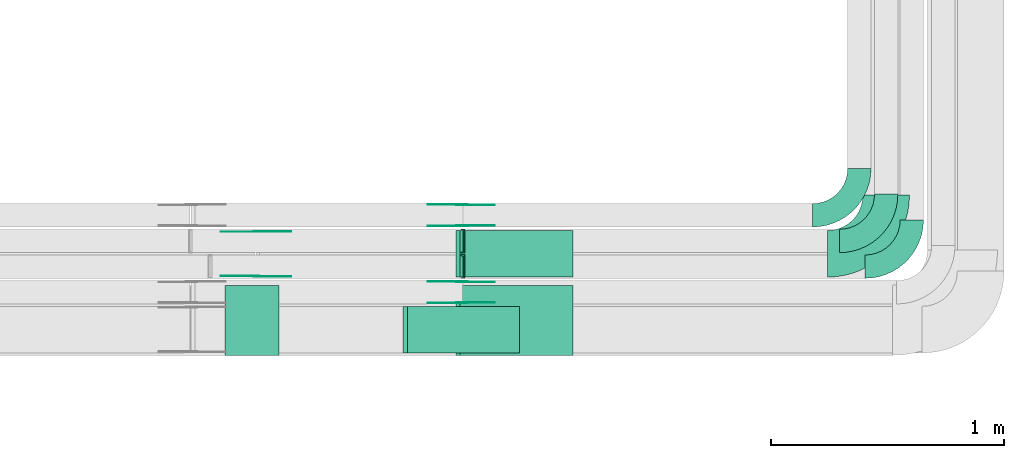
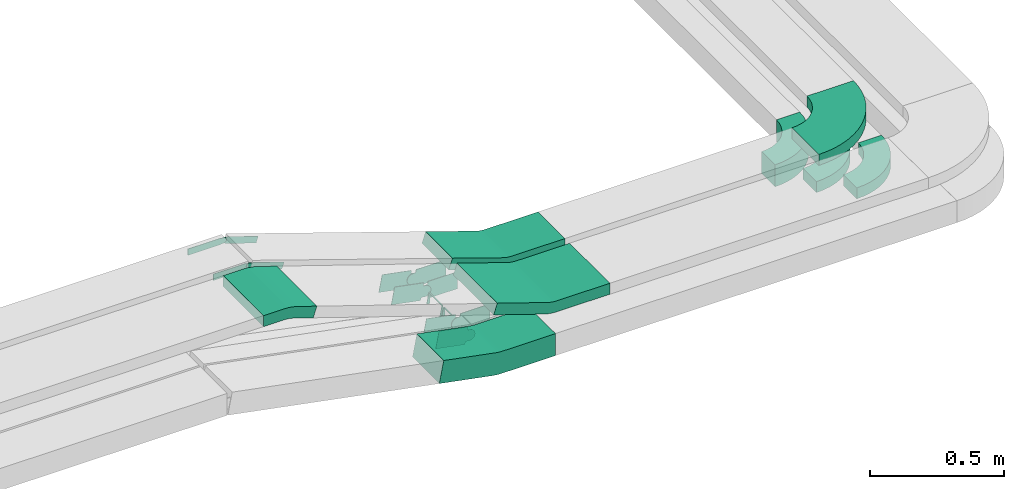
# One storey, part 25 of 28: 22 flow fittings.
"""IFC2X3 building model written with IfcOpenShell, lengths in millimetres."""

from ifc_helpers import new_model, entity, si_unit, converted_unit, derived_unit, direction, frame, frame_2d, origin, place, context, subcontext, project, spatial, polyline, circle_curve, parameter, trimmed, segment, composite_curve, outline, extrude, faceted_brep, source, transform, mapped, material, type_object, type_shapes, element, save


model = new_model("IFC2X3")

# Units and contexts
model_context = context("Model", 3, precision=0.01, world=origin(), true_north=direction((6.12303176911189e-17, 1.0)))
body_context = subcontext(model_context, "Body", "Model", "MODEL_VIEW")
ifc_project = project(units=[si_unit("LENGTHUNIT", "METRE", prefix="MILLI"), si_unit("AREAUNIT", "SQUARE_METRE"), si_unit("VOLUMEUNIT", "CUBIC_METRE"), converted_unit("PLANEANGLEUNIT", "DEGREE", entity("IfcRatioMeasure", 0.0174532925199433), si_unit("PLANEANGLEUNIT", "RADIAN"), dimensions=[0, 0, 0, 0, 0, 0, 0]), si_unit("MASSUNIT", "GRAM", prefix="KILO"), derived_unit("MASSDENSITYUNIT", [(si_unit("MASSUNIT", "GRAM", prefix="KILO"), 1), (si_unit("LENGTHUNIT", "METRE"), -3)]), derived_unit("MOMENTOFINERTIAUNIT", [(si_unit("LENGTHUNIT", "METRE"), 4)]), si_unit("TIMEUNIT", "SECOND"), si_unit("FREQUENCYUNIT", "HERTZ"), si_unit("THERMODYNAMICTEMPERATUREUNIT", "DEGREE_CELSIUS"), derived_unit("THERMALTRANSMITTANCEUNIT", [(si_unit("MASSUNIT", "GRAM", prefix="KILO"), 1), (si_unit("THERMODYNAMICTEMPERATUREUNIT", "KELVIN"), -1), (si_unit("TIMEUNIT", "SECOND"), -3)]), derived_unit("VOLUMETRICFLOWRATEUNIT", [(si_unit("LENGTHUNIT", "METRE"), 3), (si_unit("TIMEUNIT", "SECOND"), -1)]), derived_unit("MASSFLOWRATEUNIT", [(si_unit("MASSUNIT", "GRAM", prefix="KILO"), 1), (si_unit("TIMEUNIT", "SECOND"), -1)]), derived_unit("ROTATIONALFREQUENCYUNIT", [(si_unit("TIMEUNIT", "SECOND"), -1)]), si_unit("ELECTRICCURRENTUNIT", "AMPERE"), si_unit("ELECTRICVOLTAGEUNIT", "VOLT"), si_unit("POWERUNIT", "WATT"), si_unit("FORCEUNIT", "NEWTON", prefix="KILO"), si_unit("ILLUMINANCEUNIT", "LUX"), si_unit("LUMINOUSFLUXUNIT", "LUMEN"), si_unit("LUMINOUSINTENSITYUNIT", "CANDELA"), derived_unit("USERDEFINED", [(si_unit("MASSUNIT", "GRAM", prefix="KILO"), -1), (si_unit("LENGTHUNIT", "METRE"), -2), (si_unit("TIMEUNIT", "SECOND"), 3), (si_unit("LUMINOUSFLUXUNIT", "LUMEN"), 1)]), derived_unit("LINEARVELOCITYUNIT", [(si_unit("LENGTHUNIT", "METRE"), 1), (si_unit("TIMEUNIT", "SECOND"), -1)]), si_unit("PRESSUREUNIT", "PASCAL"), derived_unit("USERDEFINED", [(si_unit("LENGTHUNIT", "METRE"), -2), (si_unit("MASSUNIT", "GRAM", prefix="KILO"), 1), (si_unit("TIMEUNIT", "SECOND"), -2)]), derived_unit("LINEARFORCEUNIT", [(si_unit("MASSUNIT", "GRAM", prefix="KILO"), 1), (si_unit("LENGTHUNIT", "METRE"), 1), (si_unit("TIMEUNIT", "SECOND"), -2), (si_unit("LENGTHUNIT", "METRE"), -1)]), derived_unit("PLANARFORCEUNIT", [(si_unit("MASSUNIT", "GRAM", prefix="KILO"), 1), (si_unit("LENGTHUNIT", "METRE"), 1), (si_unit("TIMEUNIT", "SECOND"), -2), (si_unit("LENGTHUNIT", "METRE"), -2)])], contexts=[model_context])

# Site, building, storey
site_placement = place(None, origin())
site = spatial("IfcSite", under=ifc_project, at=site_placement, CompositionType="ELEMENT")
building_placement = place(site_placement, origin())
building = spatial("IfcBuilding", under=site, at=building_placement, CompositionType="ELEMENT")
storey_placement = place(building_placement, frame((0.0, 0.0, 15900.0)))
storey = spatial("IfcBuildingStorey", under=building, at=storey_placement, CompositionType="ELEMENT", Elevation=15900.0)

# Flow fittings
ifc_material_1 = material()
cable_carrier_fitting_type_1 = type_object("IfcCableCarrierFittingType", PredefinedType="NOTDEFINED", material=ifc_material_1)
shared_shape_1 = source(origin(), body_context, "Body", "Brep", [
    faceted_brep([(-5.06, 25.0, 50.0), (-5.06, 25.0, -50.0), (-5.06, -25.0, -50.0), (-5.06, -25.0, -47.46), (-5.06, 22.46, -47.46), (-5.06, 22.46, 47.46), (-5.06, -25.0, 47.46), (-5.06, -25.0, 50.0), (-0.05, 25.51, 50.0), (9.97, -23.48, 50.0), (9.97, -23.48, 47.46), (0.46, 23.02, 47.46), (0.46, 23.02, -47.46), (9.97, -23.48, -47.46), (9.97, -23.48, -50.0), (-0.05, 25.51, -50.0), (-2.53, 25.0, 50.0), (-2.53, 25.0, -50.0), (2.53, -25.0, -50.0), (2.53, -25.0, -47.46), (-2.27, 22.46, -47.46), (-2.27, 22.46, 47.46), (2.53, -25.0, 47.46), (2.53, -25.0, 50.0)], [[[0, 1, 2, 3, 4, 5, 6, 7]], [[8, 9, 10, 11, 12, 13, 14, 15]], [[1, 0, 16, 17]], [[2, 1, 17, 15, 14, 18]], [[3, 2, 18, 19]], [[4, 3, 19, 13, 12, 20]], [[5, 4, 20, 21]], [[6, 5, 21, 11, 10, 22]], [[7, 6, 22, 23]], [[0, 7, 23, 9, 8, 16]], [[17, 16, 8, 15]], [[19, 18, 14, 13]], [[21, 20, 12, 11]], [[23, 22, 10, 9]]]),
])
type_shapes(cable_carrier_fitting_type_1, [shared_shape_1])
flow_fitting_1_placement = place(storey_placement, frame((66661.56, 8844.97, 2620.87), z_axis=(0.0, 1.0, 0.0), x_axis=(-1.0, 0.0, 0.0)))
element("IfcFlowFitting", 1, at=flow_fitting_1_placement, inside=storey, type_object=cable_carrier_fitting_type_1, material=ifc_material_1, context=body_context, shape_type="MappedRepresentation", body=[
    mapped(shared_shape_1, transform((0.0, 0.0, 0.0), scale=1.0)),
])
cable_carrier_fitting_type_2 = type_object("IfcCableCarrierFittingType", PredefinedType="NOTDEFINED", material=ifc_material_1)
shared_shape_2 = source(origin(), body_context, "Body", "Brep", [
    faceted_brep([(-4.7, 25.0, 50.0), (-4.7, 25.0, -50.0), (-4.7, -25.0, -50.0), (-4.7, -25.0, -47.46), (-4.7, 22.46, -47.46), (-4.7, 22.46, 47.46), (-4.7, -25.0, 47.46), (-4.7, -25.0, 50.0), (-0.04, 25.44, 50.0), (9.28, -23.69, 50.0), (9.28, -23.69, 47.46), (0.43, 22.94, 47.46), (0.43, 22.94, -47.46), (9.28, -23.69, -47.46), (9.28, -23.69, -50.0), (-0.04, 25.44, -50.0), (-2.35, 25.0, 50.0), (-2.35, 25.0, -50.0), (2.35, -25.0, -50.0), (2.35, -25.0, -47.46), (-2.11, 22.46, -47.46), (-2.11, 22.46, 47.46), (2.35, -25.0, 47.46), (2.35, -25.0, 50.0)], [[[0, 1, 2, 3, 4, 5, 6, 7]], [[8, 9, 10, 11, 12, 13, 14, 15]], [[1, 0, 16, 17]], [[2, 1, 17, 15, 14, 18]], [[3, 2, 18, 19]], [[4, 3, 19, 13, 12, 20]], [[5, 4, 20, 21]], [[6, 5, 21, 11, 10, 22]], [[7, 6, 22, 23]], [[0, 7, 23, 9, 8, 16]], [[17, 16, 8, 15]], [[19, 18, 14, 13]], [[21, 20, 12, 11]], [[23, 22, 10, 9]]]),
])
type_shapes(cable_carrier_fitting_type_2, [shared_shape_2])
flow_fitting_2_placement = place(storey_placement, frame((66661.56, 8954.97, 2620.87), z_axis=(0.0, 1.0, 0.0), x_axis=(-1.0, 0.0, 0.0)))
element("IfcFlowFitting", 2, at=flow_fitting_2_placement, inside=storey, type_object=cable_carrier_fitting_type_2, material=ifc_material_1, context=body_context, shape_type="MappedRepresentation", body=[
    mapped(shared_shape_2, transform((0.0, 0.0, 0.0), scale=1.0)),
])
cable_carrier_fitting_type_3 = type_object("IfcCableCarrierFittingType", Name="470_DKC_S5_Variable Angle Elbow 0-45:-", PredefinedType="NOTDEFINED", material=ifc_material_1)
shared_shape_3 = source(origin(), body_context, "Body", "SweptSolid", [
    extrude(outline(composite_curve([segment(polyline([(-100.75, -150.25), (-99.75, -150.25)]), True, "CONTINUOUS"), segment(trimmed(circle_curve(frame_2d((-99.75, 99.75), x_axis=(0.0, -1.0)), 250.0), [parameter(0.0)], [parameter(90.0000000000001)], True, "PARAMETER"), True, "CONTINUOUS"), segment(polyline([(150.25, 99.75), (150.25, 100.75)]), True, "CONTINUOUS"), segment(polyline([(150.25, 100.75), (50.25, 100.75)]), True, "CONTINUOUS"), segment(polyline([(50.25, 100.75), (50.25, 99.75)]), True, "CONTINUOUS"), segment(trimmed(circle_curve(frame_2d((-99.75, 99.75), x_axis=(0.0, -1.0)), 150.0), [parameter(0.0)], [parameter(90.0000000000001)], True, "PARAMETER"), False, "CONTINUOUS"), segment(polyline([(-99.75, -50.25), (-100.75, -50.25)]), True, "CONTINUOUS"), segment(polyline([(-100.75, -50.25), (-100.75, -150.25)]), True, "CONTINUOUS")], self_intersect=False)), frame((-100.25, 100.25, -25.0)), (0.0, 0.0, 1.0), 49.9999999999997),
])
type_shapes(cable_carrier_fitting_type_3, [shared_shape_3])
for number, where, name in (
    (3, (68472.94, 8954.97, 2620.87), "470_DKC_S5_Variable Angle Elbow 0-45:-"),
    (4, (68582.94, 8844.97, 2620.87), "470_DKC_S5_Variable Angle Elbow 0-45:-"),
):
    element("IfcFlowFitting", number, at=place(storey_placement, frame(where)), inside=storey, type_object=cable_carrier_fitting_type_3, material=ifc_material_1, Name=name, ObjectType="470_DKC_S5_Variable Angle Elbow 0-45:-", context=body_context, shape_type="MappedRepresentation", body=[
        mapped(shared_shape_3, transform((0.0, 0.0, 0.0), scale=1.0)),
    ])
ifc_material_2 = material(Name="G")
cable_carrier_fitting_type_4 = type_object("IfcCableCarrierFittingType", PredefinedType="NOTDEFINED", material=ifc_material_2)
shared_shape_4 = source(origin(), body_context, "Body", "SweptSolid", [
    extrude(outline(composite_curve([segment(trimmed(circle_curve(frame_2d((-44.59, 0.0), x_axis=(1.0, 0.0)), 12.5), [parameter(90.0000000000007)], [parameter(270.0)], True, "PARAMETER"), True, "CONTINUOUS"), segment(polyline([(-44.59, -12.5), (-33.09, -12.5)]), True, "CONTINUOUS"), segment(polyline([(-33.09, -12.5), (-31.23, -14.5)]), True, "CONTINUOUS"), segment(polyline([(-31.23, -14.5), (108.91, -14.5)]), True, "CONTINUOUS"), segment(polyline([(108.91, -14.5), (108.91, 14.5)]), True, "CONTINUOUS"), segment(polyline([(108.91, 14.5), (-31.23, 14.5)]), True, "CONTINUOUS"), segment(polyline([(-31.23, 14.5), (-33.09, 12.5)]), True, "CONTINUOUS"), segment(polyline([(-33.09, 12.5), (-44.59, 12.5)]), True, "CONTINUOUS")], self_intersect=False)), frame((44.59, 0.0, 0.0), z_axis=(0.0, 0.0, -1.0), x_axis=(1.0, 0.0, 0.0)), (0.0, 0.0, -1.0), 2.0),
])
type_shapes(cable_carrier_fitting_type_4, [shared_shape_4])
flow_fitting_3_placement = place(storey_placement, frame((65773.82, 8995.61, 3200.0), z_axis=(0.0, 1.0, 0.0), x_axis=(0.947026352753384, 0.0, -0.321155861211693)))
element("IfcFlowFitting", 5, at=flow_fitting_3_placement, inside=storey, type_object=cable_carrier_fitting_type_4, material=ifc_material_2, context=body_context, shape_type="MappedRepresentation", body=[
    mapped(shared_shape_4, transform((0.0, 0.0, 0.0), scale=1.0)),
])
cable_carrier_fitting_type_5 = type_object("IfcCableCarrierFittingType", PredefinedType="NOTDEFINED", material=ifc_material_2)
type_shapes(cable_carrier_fitting_type_5, [shared_shape_4])
flow_fitting_4_placement = place(storey_placement, frame((65773.82, 8806.69, 3200.0), z_axis=(0.0, -1.0, 0.0), x_axis=(-1.0, 0.0, 0.0)))
element("IfcFlowFitting", 6, at=flow_fitting_4_placement, inside=storey, type_object=cable_carrier_fitting_type_5, material=ifc_material_2, context=body_context, shape_type="MappedRepresentation", body=[
    mapped(shared_shape_4, transform((0.0, 0.0, 0.0), scale=1.0)),
])
cable_carrier_fitting_type_6 = type_object("IfcCableCarrierFittingType", PredefinedType="NOTDEFINED", material=ifc_material_2)
shared_shape_5 = source(origin(), body_context, "Body", "SweptSolid", [
    extrude(outline(composite_curve([segment(trimmed(circle_curve(frame_2d((-44.59, 0.0), x_axis=(1.0, 0.0)), 12.5), [parameter(90.0000000000007)], [parameter(270.0)], True, "PARAMETER"), True, "CONTINUOUS"), segment(polyline([(-44.59, -12.5), (-33.09, -12.5)]), True, "CONTINUOUS"), segment(polyline([(-33.09, -12.5), (-31.23, -14.5)]), True, "CONTINUOUS"), segment(polyline([(-31.23, -14.5), (108.91, -14.5)]), True, "CONTINUOUS"), segment(polyline([(108.91, -14.5), (108.91, 14.5)]), True, "CONTINUOUS"), segment(polyline([(108.91, 14.5), (-31.23, 14.5)]), True, "CONTINUOUS"), segment(polyline([(-31.23, 14.5), (-33.09, 12.5)]), True, "CONTINUOUS"), segment(polyline([(-33.09, 12.5), (-44.59, 12.5)]), True, "CONTINUOUS")], self_intersect=False)), frame((44.59, 0.0, 0.0)), (0.0, 0.0, 1.0), 2.0),
])
type_shapes(cable_carrier_fitting_type_6, [shared_shape_5])
flow_fitting_5_placement = place(storey_placement, frame((65773.82, 8804.69, 3200.0), z_axis=(0.0, -1.0, 0.0), x_axis=(0.947026352753384, 0.0, -0.321155861211693)))
element("IfcFlowFitting", 7, at=flow_fitting_5_placement, inside=storey, type_object=cable_carrier_fitting_type_6, material=ifc_material_2, context=body_context, shape_type="MappedRepresentation", body=[
    mapped(shared_shape_5, transform((0.0, 0.0, 0.0), scale=1.0)),
])
cable_carrier_fitting_type_7 = type_object("IfcCableCarrierFittingType", PredefinedType="NOTDEFINED", material=ifc_material_2)
type_shapes(cable_carrier_fitting_type_7, [shared_shape_5])
flow_fitting_6_placement = place(storey_placement, frame((65773.82, 8993.61, 3200.0), z_axis=(0.0, 1.0, 0.0), x_axis=(-1.0, 0.0, 0.0)))
element("IfcFlowFitting", 8, at=flow_fitting_6_placement, inside=storey, type_object=cable_carrier_fitting_type_7, material=ifc_material_2, context=body_context, shape_type="MappedRepresentation", body=[
    mapped(shared_shape_5, transform((0.0, 0.0, 0.0), scale=1.0)),
])
cable_carrier_fitting_type_8 = type_object("IfcCableCarrierFittingType", Name="470_DKC_S5_Variable Angle Elbow 0-45:-", PredefinedType="NOTDEFINED", material=ifc_material_1)
shared_shape_6 = source(origin(), body_context, "Body", "SweptSolid", [
    extrude(outline(composite_curve([segment(polyline([(-100.75, -150.25), (-99.75, -150.25)]), True, "CONTINUOUS"), segment(trimmed(circle_curve(frame_2d((-99.75, 99.75), x_axis=(0.0, -1.0)), 250.0), [parameter(0.0)], [parameter(90.0000000000001)], True, "PARAMETER"), True, "CONTINUOUS"), segment(polyline([(150.25, 99.75), (150.25, 100.75)]), True, "CONTINUOUS"), segment(polyline([(150.25, 100.75), (50.25, 100.75)]), True, "CONTINUOUS"), segment(polyline([(50.25, 100.75), (50.25, 99.75)]), True, "CONTINUOUS"), segment(trimmed(circle_curve(frame_2d((-99.75, 99.75), x_axis=(0.0, -1.0)), 150.0), [parameter(0.0)], [parameter(90.0000000000001)], True, "PARAMETER"), False, "CONTINUOUS"), segment(polyline([(-99.75, -50.25), (-100.75, -50.25)]), True, "CONTINUOUS"), segment(polyline([(-100.75, -50.25), (-100.75, -150.25)]), True, "CONTINUOUS")], self_intersect=False)), frame((-100.25, 100.25, -50.0)), (0.0, 0.0, 1.0), 100.0),
])
type_shapes(cable_carrier_fitting_type_8, [shared_shape_6])
flow_fitting_7_placement = place(storey_placement, frame((68357.94, 9064.97, 2645.87)))
element("IfcFlowFitting", 9, at=flow_fitting_7_placement, inside=storey, type_object=cable_carrier_fitting_type_8, material=ifc_material_1, Name="470_DKC_S5_Variable Angle Elbow 0-45:-", ObjectType="470_DKC_S5_Variable Angle Elbow 0-45:-", context=body_context, shape_type="MappedRepresentation", body=[
    mapped(shared_shape_6, transform((0.0, 0.0, 0.0), scale=1.0)),
])
cable_carrier_fitting_type_9 = type_object("IfcCableCarrierFittingType", Name="470_DKC_S5_Variable Angle Elbow 0-45:-", PredefinedType="NOTDEFINED", material=ifc_material_1)
shared_shape_7 = source(origin(), body_context, "Body", "SweptSolid", [
    extrude(outline(composite_curve([segment(polyline([(-125.75, -225.25), (-124.75, -225.25)]), True, "CONTINUOUS"), segment(trimmed(circle_curve(frame_2d((-124.75, 124.75), x_axis=(0.0, -1.0)), 350.0), [parameter(0.0)], [parameter(90.0)], True, "PARAMETER"), True, "CONTINUOUS"), segment(polyline([(225.25, 124.75), (225.25, 125.75)]), True, "CONTINUOUS"), segment(polyline([(225.25, 125.75), (25.25, 125.75)]), True, "CONTINUOUS"), segment(polyline([(25.25, 125.75), (25.25, 124.75)]), True, "CONTINUOUS"), segment(trimmed(circle_curve(frame_2d((-124.75, 124.75), x_axis=(0.0, -1.0)), 150.0), [parameter(0.0)], [parameter(90.0)], True, "PARAMETER"), False, "CONTINUOUS"), segment(polyline([(-124.75, -25.25), (-125.75, -25.25)]), True, "CONTINUOUS"), segment(polyline([(-125.75, -25.25), (-125.75, -225.25)]), True, "CONTINUOUS")], self_intersect=False)), frame((-125.25, 125.25, -25.0)), (0.0, 0.0, 1.0), 50.000000000001),
])
type_shapes(cable_carrier_fitting_type_9, [shared_shape_7])
flow_fitting_8_placement = place(storey_placement, frame((68472.94, 8900.15, 2825.87)))
element("IfcFlowFitting", 10, at=flow_fitting_8_placement, inside=storey, type_object=cable_carrier_fitting_type_9, material=ifc_material_1, Name="470_DKC_S5_Variable Angle Elbow 0-45:-", ObjectType="470_DKC_S5_Variable Angle Elbow 0-45:-", context=body_context, shape_type="MappedRepresentation", body=[
    mapped(shared_shape_7, transform((0.0, 0.0, 0.0), scale=1.0)),
])
cable_carrier_fitting_type_10 = type_object("IfcCableCarrierFittingType", PredefinedType="NOTDEFINED", material=ifc_material_2)
shared_shape_8 = source(origin(), body_context, "Body", "SweptSolid", [
    extrude(outline(composite_curve([segment(trimmed(circle_curve(frame_2d((-41.47, 0.0), x_axis=(1.0, 0.0)), 25.0), [parameter(90.0000000000007)], [parameter(270.0)], True, "PARAMETER"), True, "CONTINUOUS"), segment(polyline([(-41.47, -25.0), (-29.97, -25.0)]), True, "CONTINUOUS"), segment(polyline([(-29.97, -25.0), (-28.1, -38.5)]), True, "CONTINUOUS"), segment(polyline([(-28.1, -38.5), (99.53, -38.5)]), True, "CONTINUOUS"), segment(polyline([(99.53, -38.5), (99.53, 38.5)]), True, "CONTINUOUS"), segment(polyline([(99.53, 38.5), (-28.1, 38.5)]), True, "CONTINUOUS"), segment(polyline([(-28.1, 38.5), (-29.97, 25.0)]), True, "CONTINUOUS"), segment(polyline([(-29.97, 25.0), (-41.47, 25.0)]), True, "CONTINUOUS")], self_intersect=False)), frame((41.47, 0.0, 0.0), z_axis=(0.0, 0.0, -1.0), x_axis=(1.0, 0.0, 0.0)), (0.0, 0.0, -1.0), 2.0),
])
type_shapes(cable_carrier_fitting_type_10, [shared_shape_8])
flow_fitting_9_placement = place(storey_placement, frame((66654.18, 8780.43, 2645.87), z_axis=(0.0, 1.0, 0.0), x_axis=(-0.982035536310358, 0.0, 0.188696066264316)))
element("IfcFlowFitting", 11, at=flow_fitting_9_placement, inside=storey, type_object=cable_carrier_fitting_type_10, material=ifc_material_2, context=body_context, shape_type="MappedRepresentation", body=[
    mapped(shared_shape_8, transform((0.0, 0.0, 0.0), scale=1.0)),
])
cable_carrier_fitting_type_11 = type_object("IfcCableCarrierFittingType", PredefinedType="NOTDEFINED", material=ifc_material_2)
type_shapes(cable_carrier_fitting_type_11, [shared_shape_8])
flow_fitting_10_placement = place(storey_placement, frame((66654.18, 8691.51, 2645.87), z_axis=(0.0, -1.0, 0.0), x_axis=(1.0, 0.0, 0.0)))
element("IfcFlowFitting", 12, at=flow_fitting_10_placement, inside=storey, type_object=cable_carrier_fitting_type_11, material=ifc_material_2, context=body_context, shape_type="MappedRepresentation", body=[
    mapped(shared_shape_8, transform((0.0, 0.0, 0.0), scale=1.0)),
])
flow_fitting_11_placement = place(storey_placement, frame((66654.18, 9110.43, 2645.87), z_axis=(0.0, 1.0, 0.0), x_axis=(-0.982035536310358, 0.0, 0.188696066264316)))
element("IfcFlowFitting", 13, at=flow_fitting_11_placement, inside=storey, type_object=cable_carrier_fitting_type_10, material=ifc_material_2, context=body_context, shape_type="MappedRepresentation", body=[
    mapped(shared_shape_8, transform((0.0, 0.0, 0.0), scale=1.0)),
])
flow_fitting_12_placement = place(storey_placement, frame((66654.18, 9021.51, 2645.87), z_axis=(0.0, -1.0, 0.0), x_axis=(1.0, 0.0, 0.0)))
element("IfcFlowFitting", 14, at=flow_fitting_12_placement, inside=storey, type_object=cable_carrier_fitting_type_11, material=ifc_material_2, context=body_context, shape_type="MappedRepresentation", body=[
    mapped(shared_shape_8, transform((0.0, 0.0, 0.0), scale=1.0)),
])
cable_carrier_fitting_type_12 = type_object("IfcCableCarrierFittingType", PredefinedType="NOTDEFINED", material=ifc_material_2)
shared_shape_9 = source(origin(), body_context, "Body", "SweptSolid", [
    extrude(outline(composite_curve([segment(trimmed(circle_curve(frame_2d((-41.47, 0.0), x_axis=(1.0, 0.0)), 25.0), [parameter(90.0000000000007)], [parameter(270.0)], True, "PARAMETER"), True, "CONTINUOUS"), segment(polyline([(-41.47, -25.0), (-29.97, -25.0)]), True, "CONTINUOUS"), segment(polyline([(-29.97, -25.0), (-28.1, -38.5)]), True, "CONTINUOUS"), segment(polyline([(-28.1, -38.5), (99.53, -38.5)]), True, "CONTINUOUS"), segment(polyline([(99.53, -38.5), (99.53, 38.5)]), True, "CONTINUOUS"), segment(polyline([(99.53, 38.5), (-28.1, 38.5)]), True, "CONTINUOUS"), segment(polyline([(-28.1, 38.5), (-29.97, 25.0)]), True, "CONTINUOUS"), segment(polyline([(-29.97, 25.0), (-41.47, 25.0)]), True, "CONTINUOUS")], self_intersect=False)), frame((41.47, 0.0, 0.0)), (0.0, 0.0, 1.0), 2.0),
])
type_shapes(cable_carrier_fitting_type_12, [shared_shape_9])
flow_fitting_13_placement = place(storey_placement, frame((66654.18, 8689.51, 2645.87), z_axis=(0.0, -1.0, 0.0), x_axis=(-0.982035536310358, 0.0, 0.188696066264316)))
element("IfcFlowFitting", 15, at=flow_fitting_13_placement, inside=storey, type_object=cable_carrier_fitting_type_12, material=ifc_material_2, context=body_context, shape_type="MappedRepresentation", body=[
    mapped(shared_shape_9, transform((0.0, 0.0, 0.0), scale=1.0)),
])
cable_carrier_fitting_type_13 = type_object("IfcCableCarrierFittingType", PredefinedType="NOTDEFINED", material=ifc_material_2)
type_shapes(cable_carrier_fitting_type_13, [shared_shape_9])
flow_fitting_14_placement = place(storey_placement, frame((66654.18, 8778.43, 2645.87), z_axis=(0.0, 1.0, 0.0), x_axis=(1.0, 0.0, 0.0)))
element("IfcFlowFitting", 16, at=flow_fitting_14_placement, inside=storey, type_object=cable_carrier_fitting_type_13, material=ifc_material_2, context=body_context, shape_type="MappedRepresentation", body=[
    mapped(shared_shape_9, transform((0.0, 0.0, 0.0), scale=1.0)),
])
flow_fitting_15_placement = place(storey_placement, frame((66654.18, 9019.51, 2645.87), z_axis=(0.0, -1.0, 0.0), x_axis=(-0.982035536310358, 0.0, 0.188696066264316)))
element("IfcFlowFitting", 17, at=flow_fitting_15_placement, inside=storey, type_object=cable_carrier_fitting_type_12, material=ifc_material_2, context=body_context, shape_type="MappedRepresentation", body=[
    mapped(shared_shape_9, transform((0.0, 0.0, 0.0), scale=1.0)),
])
flow_fitting_16_placement = place(storey_placement, frame((66654.18, 9108.43, 2645.87), z_axis=(0.0, 1.0, 0.0), x_axis=(1.0, 0.0, 0.0)))
element("IfcFlowFitting", 18, at=flow_fitting_16_placement, inside=storey, type_object=cable_carrier_fitting_type_13, material=ifc_material_2, context=body_context, shape_type="MappedRepresentation", body=[
    mapped(shared_shape_9, transform((0.0, 0.0, 0.0), scale=1.0)),
])
cable_carrier_fitting_type_14 = type_object("IfcCableCarrierFittingType", Name="470_DKC_S5_CS 90 internal vertical angle:-", PredefinedType="NOTDEFINED", material=ifc_material_1)
shared_shape_10 = source(origin(), body_context, "Body", "SweptSolid", [
    extrude(outline(composite_curve([segment(polyline([(-246.32, -62.42), (-14.53, -62.42)]), True, "CONTINUOUS"), segment(trimmed(circle_curve(frame_2d((-14.53, 152.58), x_axis=(0.0, -1.0)), 214.999999999999), [parameter(0.0)], [parameter(10.876697894602)], True, "PARAMETER"), True, "CONTINUOUS"), segment(polyline([(26.04, -58.55), (253.68, -14.82)]), True, "CONTINUOUS"), segment(polyline([(253.68, -14.82), (234.81, 83.39)]), True, "CONTINUOUS"), segment(polyline([(234.81, 83.39), (7.17, 39.65)]), True, "CONTINUOUS"), segment(trimmed(circle_curve(frame_2d((-14.53, 152.58), x_axis=(0.0, -1.0)), 114.999999999999), [parameter(0.0)], [parameter(10.876697894602)], True, "PARAMETER"), False, "CONTINUOUS"), segment(polyline([(-14.53, 37.58), (-246.32, 37.58)]), True, "CONTINUOUS"), segment(polyline([(-246.32, 37.58), (-246.32, -62.42)]), True, "CONTINUOUS")], self_intersect=False)), frame((-1.18, 12.42, -100.0)), (0.0, 0.0, 1.0), 200.0),
])
type_shapes(cable_carrier_fitting_type_14, [shared_shape_10])
flow_fitting_17_placement = place(storey_placement, frame((66654.18, 8574.97, 2645.87), z_axis=(0.0, 1.0, 0.0), x_axis=(-1.0, 0.0, 0.0)))
element("IfcFlowFitting", 19, at=flow_fitting_17_placement, inside=storey, type_object=cable_carrier_fitting_type_14, material=ifc_material_1, Name="470_DKC_S5_CS 90 internal vertical angle:-", ObjectType="470_DKC_S5_CS 90 internal vertical angle:-", context=body_context, shape_type="MappedRepresentation", body=[
    mapped(shared_shape_10, transform((0.0, 0.0, 0.0), scale=1.0)),
])
cable_carrier_fitting_type_15 = type_object("IfcCableCarrierFittingType", Name="470_DKC_S5_CS 90 internal vertical angle:-", PredefinedType="NOTDEFINED", material=ifc_material_1)
shared_shape_11 = source(origin(), body_context, "Body", "SweptSolid", [
    extrude(outline(composite_curve([segment(polyline([(-248.99, -46.74), (-19.18, -46.74)]), True, "CONTINUOUS"), segment(trimmed(circle_curve(frame_2d((-19.18, 118.26), x_axis=(0.0, -1.0)), 164.999999999999), [parameter(0.0)], [parameter(18.4219865734393)], True, "PARAMETER"), True, "CONTINUOUS"), segment(polyline([(32.97, -38.29), (251.01, 34.34)]), True, "CONTINUOUS"), segment(polyline([(251.01, 34.34), (235.21, 81.78)]), True, "CONTINUOUS"), segment(polyline([(235.21, 81.78), (17.16, 9.15)]), True, "CONTINUOUS"), segment(trimmed(circle_curve(frame_2d((-19.18, 118.26), x_axis=(0.0, -1.0)), 114.999999999999), [parameter(0.0)], [parameter(18.4219865734393)], True, "PARAMETER"), False, "CONTINUOUS"), segment(polyline([(-19.18, 3.26), (-248.99, 3.26)]), True, "CONTINUOUS"), segment(polyline([(-248.99, 3.26), (-248.99, -46.74)]), True, "CONTINUOUS")], self_intersect=False)), frame((-3.53, 21.74, -150.0)), (0.0, 0.0, 1.0), 300.0),
])
type_shapes(cable_carrier_fitting_type_15, [shared_shape_11])
flow_fitting_18_placement = place(storey_placement, frame((66877.05, 8615.15, 2825.87), z_axis=(0.0, 1.0, 0.0), x_axis=(-1.0, 0.0, 0.0)))
element("IfcFlowFitting", 20, at=flow_fitting_18_placement, inside=storey, type_object=cable_carrier_fitting_type_15, material=ifc_material_1, Name="470_DKC_S5_CS 90 internal vertical angle:-", ObjectType="470_DKC_S5_CS 90 internal vertical angle:-", context=body_context, shape_type="MappedRepresentation", body=[
    mapped(shared_shape_11, transform((0.0, 0.0, 0.0), scale=1.0)),
])
cable_carrier_fitting_type_16 = type_object("IfcCableCarrierFittingType", Name="470_DKC_S5_CD 90 external vertical angle:-", PredefinedType="NOTDEFINED", material=ifc_material_1)
shared_shape_12 = source(origin(), body_context, "Body", "SweptSolid", [
    extrude(outline(composite_curve([segment(polyline([(-112.17, -36.12), (-24.95, -36.12)]), True, "CONTINUOUS"), segment(trimmed(circle_curve(frame_2d((-24.95, 153.88), x_axis=(0.0, -1.0)), 189.999999999999), [parameter(0.0)], [parameter(18.4219865734393)], True, "PARAMETER"), True, "CONTINUOUS"), segment(polyline([(35.09, -26.38), (117.83, 1.18)]), True, "CONTINUOUS"), segment(polyline([(117.83, 1.18), (102.03, 48.62)]), True, "CONTINUOUS"), segment(polyline([(102.03, 48.62), (19.29, 21.06)]), True, "CONTINUOUS"), segment(trimmed(circle_curve(frame_2d((-24.95, 153.88), x_axis=(0.0, -1.0)), 139.999999999999), [parameter(0.0)], [parameter(18.4219865734393)], True, "PARAMETER"), False, "CONTINUOUS"), segment(polyline([(-24.95, 13.88), (-112.17, 13.88)]), True, "CONTINUOUS"), segment(polyline([(-112.17, 13.88), (-112.17, -36.12)]), True, "CONTINUOUS")], self_intersect=False)), frame((-1.8, 11.12, -150.0)), (0.0, 0.0, 1.0), 300.0),
])
type_shapes(cable_carrier_fitting_type_16, [shared_shape_12])
flow_fitting_19_placement = place(storey_placement, frame((65753.82, 8615.15, 3200.0), z_axis=(0.0, 1.0, 0.0), x_axis=(1.0, 0.0, 0.0)))
element("IfcFlowFitting", 21, at=flow_fitting_19_placement, inside=storey, type_object=cable_carrier_fitting_type_16, material=ifc_material_1, Name="470_DKC_S5_CD 90 external vertical angle:-", ObjectType="470_DKC_S5_CD 90 external vertical angle:-", context=body_context, shape_type="MappedRepresentation", body=[
    mapped(shared_shape_12, transform((0.0, 0.0, 0.0), scale=1.0)),
])
cable_carrier_fitting_type_17 = type_object("IfcCableCarrierFittingType", Name="470_DKC_S5_CS 90 internal vertical angle:-", PredefinedType="NOTDEFINED", material=ifc_material_1)
shared_shape_13 = source(origin(), body_context, "Body", "SweptSolid", [
    extrude(outline(composite_curve([segment(polyline([(-249.03, -47.14), (-19.44, -47.14)]), True, "CONTINUOUS"), segment(trimmed(circle_curve(frame_2d((-19.44, 117.86), x_axis=(0.0, -1.0)), 164.999999999999), [parameter(0.0)], [parameter(18.7328408756737)], True, "PARAMETER"), True, "CONTINUOUS"), segment(polyline([(33.55, -38.4), (250.97, 35.33)]), True, "CONTINUOUS"), segment(polyline([(250.97, 35.33), (234.92, 82.68)]), True, "CONTINUOUS"), segment(polyline([(234.92, 82.68), (17.49, 8.95)]), True, "CONTINUOUS"), segment(trimmed(circle_curve(frame_2d((-19.44, 117.86), x_axis=(0.0, -1.0)), 114.999999999999), [parameter(0.0)], [parameter(18.7328408756737)], True, "PARAMETER"), False, "CONTINUOUS"), segment(polyline([(-19.44, 2.86), (-249.03, 2.86)]), True, "CONTINUOUS"), segment(polyline([(-249.03, 2.86), (-249.03, -47.14)]), True, "CONTINUOUS")], self_intersect=False)), frame((-3.65, 22.14, -100.0)), (0.0, 0.0, 1.0), 200.0),
])
type_shapes(cable_carrier_fitting_type_17, [shared_shape_13])
flow_fitting_20_placement = place(storey_placement, frame((66877.05, 8900.15, 2825.87), z_axis=(0.0, 1.0, 0.0), x_axis=(-1.0, 0.0, 0.0)))
element("IfcFlowFitting", 22, at=flow_fitting_20_placement, inside=storey, type_object=cable_carrier_fitting_type_17, material=ifc_material_1, Name="470_DKC_S5_CS 90 internal vertical angle:-", ObjectType="470_DKC_S5_CS 90 internal vertical angle:-", context=body_context, shape_type="MappedRepresentation", body=[
    mapped(shared_shape_13, transform((0.0, 0.0, 0.0), scale=1.0)),
])

save(model, "model.ifc")
